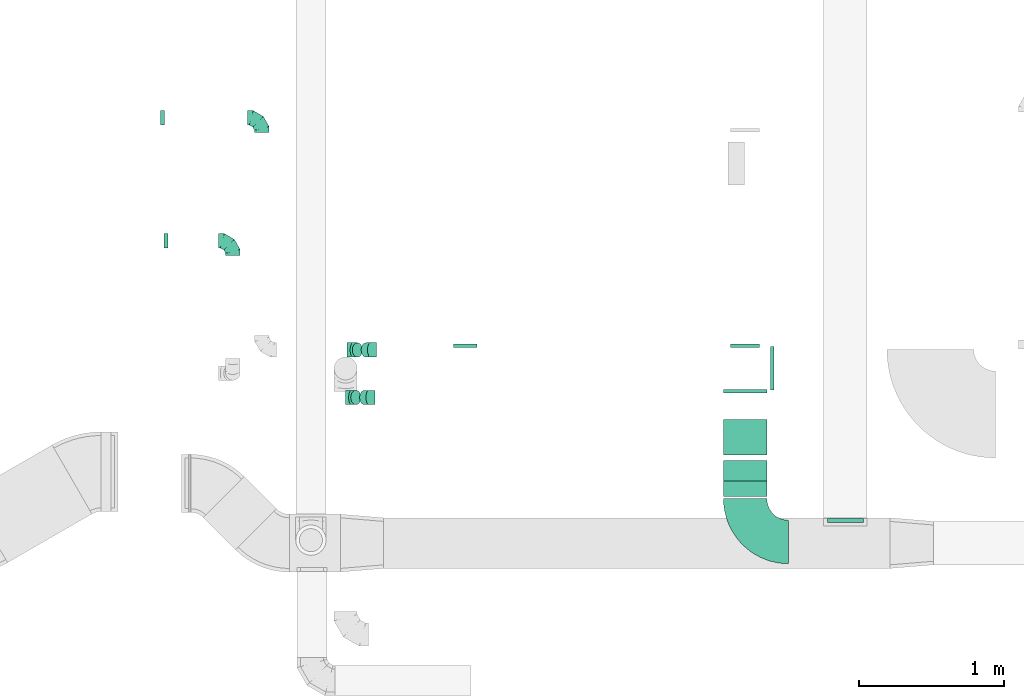
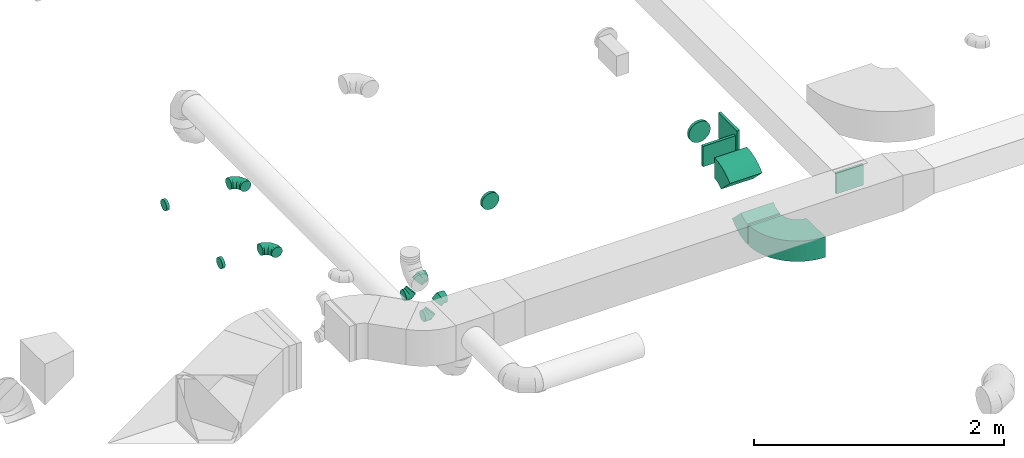
# One storey, part 48 of 62: 16 flow fittings.
"""IFC2X3 building model written with IfcOpenShell, lengths in millimetres."""

from ifc_helpers import new_model, entity, si_unit, converted_unit, derived_unit, direction, frame, frame_2d, origin, origin_2d_with_axis, place, context, subcontext, project, spatial, polyline, circle_curve, parameter, trimmed, segment, composite_curve, rectangle, outline, extrude, faceted_brep, source, transform, mapped, material, type_object, type_shapes, element, save


model = new_model("IFC2X3")

# Units and contexts
model_context = context("Model", 3, precision=0.01, world=origin(), true_north=direction((6.12303176911189e-17, 1.0)))
body_context = subcontext(model_context, "Body", "Model", "MODEL_VIEW")
ifc_project = project(units=[si_unit("LENGTHUNIT", "METRE", prefix="MILLI"), si_unit("AREAUNIT", "SQUARE_METRE"), si_unit("VOLUMEUNIT", "CUBIC_METRE"), converted_unit("PLANEANGLEUNIT", "DEGREE", entity("IfcRatioMeasure", 0.0174532925199433), si_unit("PLANEANGLEUNIT", "RADIAN"), dimensions=[0, 0, 0, 0, 0, 0, 0]), si_unit("MASSUNIT", "GRAM", prefix="KILO"), derived_unit("MASSDENSITYUNIT", [(si_unit("MASSUNIT", "GRAM", prefix="KILO"), 1), (si_unit("LENGTHUNIT", "METRE"), -3)]), derived_unit("MOMENTOFINERTIAUNIT", [(si_unit("LENGTHUNIT", "METRE"), 4)]), si_unit("TIMEUNIT", "SECOND"), si_unit("FREQUENCYUNIT", "HERTZ"), si_unit("THERMODYNAMICTEMPERATUREUNIT", "DEGREE_CELSIUS"), derived_unit("THERMALTRANSMITTANCEUNIT", [(si_unit("MASSUNIT", "GRAM", prefix="KILO"), 1), (si_unit("THERMODYNAMICTEMPERATUREUNIT", "KELVIN"), -1), (si_unit("TIMEUNIT", "SECOND"), -3)]), derived_unit("VOLUMETRICFLOWRATEUNIT", [(si_unit("LENGTHUNIT", "METRE"), 3), (si_unit("TIMEUNIT", "SECOND"), -1)]), derived_unit("MASSFLOWRATEUNIT", [(si_unit("MASSUNIT", "GRAM", prefix="KILO"), 1), (si_unit("TIMEUNIT", "SECOND"), -1)]), derived_unit("ROTATIONALFREQUENCYUNIT", [(si_unit("TIMEUNIT", "SECOND"), -1)]), si_unit("ELECTRICCURRENTUNIT", "AMPERE"), si_unit("ELECTRICVOLTAGEUNIT", "VOLT"), si_unit("POWERUNIT", "WATT"), si_unit("FORCEUNIT", "NEWTON", prefix="KILO"), si_unit("ILLUMINANCEUNIT", "LUX"), si_unit("LUMINOUSFLUXUNIT", "LUMEN"), si_unit("LUMINOUSINTENSITYUNIT", "CANDELA"), derived_unit("USERDEFINED", [(si_unit("MASSUNIT", "GRAM", prefix="KILO"), -1), (si_unit("LENGTHUNIT", "METRE"), -2), (si_unit("TIMEUNIT", "SECOND"), 3), (si_unit("LUMINOUSFLUXUNIT", "LUMEN"), 1)]), derived_unit("LINEARVELOCITYUNIT", [(si_unit("LENGTHUNIT", "METRE"), 1), (si_unit("TIMEUNIT", "SECOND"), -1)]), si_unit("PRESSUREUNIT", "PASCAL"), derived_unit("USERDEFINED", [(si_unit("LENGTHUNIT", "METRE"), -2), (si_unit("MASSUNIT", "GRAM", prefix="KILO"), 1), (si_unit("TIMEUNIT", "SECOND"), -2)]), derived_unit("LINEARFORCEUNIT", [(si_unit("MASSUNIT", "GRAM", prefix="KILO"), 1), (si_unit("LENGTHUNIT", "METRE"), 1), (si_unit("TIMEUNIT", "SECOND"), -2), (si_unit("LENGTHUNIT", "METRE"), -1)]), derived_unit("PLANARFORCEUNIT", [(si_unit("MASSUNIT", "GRAM", prefix="KILO"), 1), (si_unit("LENGTHUNIT", "METRE"), 1), (si_unit("TIMEUNIT", "SECOND"), -2), (si_unit("LENGTHUNIT", "METRE"), -2)])], contexts=[model_context])

# Site, building, storey
site_placement = place(None, origin())
site = spatial("IfcSite", under=ifc_project, at=site_placement, CompositionType="ELEMENT")
building_placement = place(site_placement, origin())
building = spatial("IfcBuilding", under=site, at=building_placement, CompositionType="ELEMENT")
storey_placement = place(building_placement, frame((0.0, 0.0, 24000.0)))
storey = spatial("IfcBuildingStorey", under=building, at=storey_placement, CompositionType="ELEMENT", Elevation=24000.0)

# Flow fittings
ifc_material = material()
duct_fitting_type_1 = type_object("IfcDuctFittingType", PredefinedType="NOTDEFINED", material=ifc_material)
shared_shape_1 = source(origin(), body_context, "Body", "SweptSolid", [
    extrude(rectangle(XDim=26.096000000001, YDim=300.0, at=origin_2d_with_axis()), frame((6.95, 0.0, -100.0)), (0.0, 0.0, 1.0), 200.0),
])
type_shapes(duct_fitting_type_1, [shared_shape_1])
flow_fitting_1_placement = place(storey_placement, frame((63690.02, 9932.41, 3625.0), z_axis=(0.0, 0.0, -1.0), x_axis=(0.0, -1.0, 0.0)))
element("IfcFlowFitting", 1, at=flow_fitting_1_placement, inside=storey, type_object=duct_fitting_type_1, material=ifc_material, context=body_context, shape_type="MappedRepresentation", body=[
    mapped(shared_shape_1, transform((0.0, 0.0, 0.0), scale=1.0)),
])
duct_fitting_type_2 = type_object("IfcDuctFittingType", PredefinedType="NOTDEFINED", material=ifc_material)
shared_shape_2 = source(origin(), body_context, "Body", "SweptSolid", [
    extrude(rectangle(XDim=250.0, YDim=26.0960000000122, at=origin_2d_with_axis()), frame((6.95, 0.0, -100.0), z_axis=(0.0, 0.0, 1.0), x_axis=(0.0, -1.0, 0.0)), (0.0, 0.0, 1.0), 200.0),
])
type_shapes(duct_fitting_type_2, [shared_shape_2])
flow_fitting_2_placement = place(storey_placement, frame((64382.65, 9025.02, 3650.0), z_axis=(0.0, 0.0, -1.0), x_axis=(0.0, 1.0, 0.0)))
element("IfcFlowFitting", 2, at=flow_fitting_2_placement, inside=storey, type_object=duct_fitting_type_2, material=ifc_material, context=body_context, shape_type="MappedRepresentation", body=[
    mapped(shared_shape_2, transform((0.0, 0.0, 0.0), scale=1.0)),
])
duct_fitting_type_3 = type_object("IfcDuctFittingType", PredefinedType="NOTDEFINED", material=ifc_material)
shared_shape_3 = source(origin(), body_context, "Body", "SweptSolid", [
    extrude(rectangle(XDim=24.9999999999999, YDim=300.0, at=origin_2d_with_axis()), frame((12.5, 0.0, -125.0)), (0.0, 0.0, 1.0), 250.0),
])
type_shapes(duct_fitting_type_3, [shared_shape_3])
flow_fitting_3_placement = place(storey_placement, frame((63865.52, 10082.41, 3625.0)))
element("IfcFlowFitting", 3, at=flow_fitting_3_placement, inside=storey, type_object=duct_fitting_type_3, material=ifc_material, context=body_context, shape_type="MappedRepresentation", body=[
    mapped(shared_shape_3, transform((0.0, 0.0, 0.0), scale=1.0)),
])
duct_fitting_type_4 = type_object("IfcDuctFittingType", PredefinedType="NOTDEFINED", material=ifc_material)
shared_shape_4 = source(origin(), body_context, "Body", "Brep", [
    faceted_brep([(-100.0, 0.0, -50.0), (-100.0, -12.94, -48.3), (-100.0, -25.0, -43.3), (-100.0, -35.36, -35.36), (-100.0, -43.3, -25.0), (-100.0, -48.3, -12.94), (-100.0, -50.0, 0.0), (-100.0, -48.3, 12.94), (-100.0, -43.3, 25.0), (-100.0, -35.36, 35.36), (-100.0, -25.0, 43.3), (-100.0, -12.94, 48.3), (-100.0, 0.0, 50.0), (-100.0, 12.94, 48.3), (-100.0, 25.0, 43.3), (-100.0, 35.36, 35.36), (-100.0, 43.3, 25.0), (-100.0, 48.3, 12.94), (-100.0, 50.0, 0.0), (-100.0, 48.3, -12.94), (-100.0, 43.3, -25.0), (-100.0, 35.36, -35.36), (-100.0, 25.0, -43.3), (-100.0, 12.94, -48.3), (-76.67, 12.94, 48.3), (-79.9, 25.0, 43.3), (-73.21, 0.0, 50.0), (-82.68, 35.36, 35.36), (-86.15, 48.3, 12.94), (-86.6, 50.0, 0.0), (-84.81, 43.3, 25.0), (-84.81, 43.3, -25.0), (-82.68, 35.36, -35.36), (-86.15, 48.3, -12.94), (-76.67, 12.94, -48.3), (-73.21, 0.0, -50.0), (-79.9, 25.0, -43.3), (-69.74, -12.94, -48.3), (-66.51, -25.0, -43.3), (-63.73, -35.36, -35.36), (-61.6, -43.3, -25.0), (-60.26, -48.3, -12.94), (-59.81, -50.0, 0.0), (-60.26, -48.3, 12.94), (-61.6, -43.3, 25.0), (-63.73, -35.36, 35.36), (-66.51, -25.0, 43.3), (-69.74, -12.94, 48.3), (-36.27, 36.27, 48.3), (-45.1, 45.1, 43.3), (-26.79, 26.79, 50.0), (-52.68, 52.68, 35.36), (-58.49, 58.49, 25.0), (-62.15, 62.15, 12.94), (-63.4, 63.4, 0.0), (-62.15, 62.15, -12.94), (-58.49, 58.49, -25.0), (-52.68, 52.68, -35.36), (-36.27, 36.27, -48.3), (-26.79, 26.79, -50.0), (-45.1, 45.1, -43.3), (-17.32, 17.32, -48.3), (-8.49, 8.49, -43.3), (-0.91, 0.91, -35.36), (4.9, -4.9, -25.0), (8.56, -8.56, -12.94), (9.81, -9.81, 0.0), (8.56, -8.56, 12.94), (4.9, -4.9, 25.0), (-0.91, 0.91, 35.36), (-8.49, 8.49, 43.3), (-17.32, 17.32, 48.3), (-12.94, 76.67, 48.3), (-25.0, 79.9, 43.3), (0.0, 73.21, 50.0), (-35.36, 82.68, 35.36), (-43.3, 84.81, 25.0), (-48.3, 86.15, 12.94), (-50.0, 86.6, 0.0), (-48.3, 86.15, -12.94), (-43.3, 84.81, -25.0), (-35.36, 82.68, -35.36), (-12.94, 76.67, -48.3), (0.0, 73.21, -50.0), (-25.0, 79.9, -43.3), (12.94, 69.74, -48.3), (25.0, 66.51, -43.3), (35.36, 63.73, -35.36), (43.3, 61.6, -25.0), (48.3, 60.26, -12.94), (50.0, 59.81, 0.0), (48.3, 60.26, 12.94), (43.3, 61.6, 25.0), (35.36, 63.73, 35.36), (25.0, 66.51, 43.3), (12.94, 69.74, 48.3), (-12.94, 100.0, -48.3), (-25.0, 100.0, -43.3), (-35.36, 100.0, -35.36), (-43.3, 100.0, -25.0), (-48.3, 100.0, -12.94), (-50.0, 100.0, 0.0), (-48.3, 100.0, 12.94), (-43.3, 100.0, 25.0), (-35.36, 100.0, 35.36), (-25.0, 100.0, 43.3), (-12.94, 100.0, 48.3), (0.0, 100.0, 50.0), (12.94, 100.0, 48.3), (25.0, 100.0, 43.3), (35.36, 100.0, 35.36), (43.3, 100.0, 25.0), (48.3, 100.0, 12.94), (50.0, 100.0, 0.0), (48.3, 100.0, -12.94), (43.3, 100.0, -25.0), (35.36, 100.0, -35.36), (25.0, 100.0, -43.3), (12.94, 100.0, -48.3), (0.0, 100.0, -50.0)], [[[0, 1, 2, 3, 4, 5, 6, 7, 8, 9, 10, 11, 12, 13, 14, 15, 16, 17, 18, 19, 20, 21, 22, 23]], [[24, 25, 14, 13]], [[26, 24, 13, 12]], [[14, 25, 27, 15]], [[28, 29, 18, 17]], [[30, 28, 17, 16]], [[15, 27, 30, 16]], [[20, 31, 32, 21]], [[33, 31, 20, 19]], [[18, 29, 33, 19]], [[34, 35, 0, 23]], [[36, 34, 23, 22]], [[32, 36, 22, 21]], [[2, 1, 37, 38]], [[3, 2, 38, 39]], [[0, 35, 37, 1]], [[5, 4, 40, 41]], [[6, 5, 41, 42]], [[3, 39, 40, 4]], [[6, 42, 43, 7]], [[7, 43, 44, 8]], [[8, 44, 45, 9]], [[10, 46, 47, 11]], [[11, 47, 26, 12]], [[10, 9, 45, 46]], [[48, 49, 25, 24]], [[50, 48, 24, 26]], [[27, 25, 49, 51]], [[52, 53, 28, 30]], [[51, 52, 30, 27]], [[29, 28, 53, 54]], [[55, 56, 31, 33]], [[54, 55, 33, 29]], [[57, 32, 31, 56]], [[58, 59, 35, 34]], [[60, 58, 34, 36]], [[57, 60, 36, 32]], [[37, 35, 59, 61]], [[38, 37, 61, 62]], [[39, 38, 62, 63]], [[41, 40, 64, 65]], [[42, 41, 65, 66]], [[63, 64, 40, 39]], [[43, 42, 66, 67]], [[44, 43, 67, 68]], [[68, 69, 45, 44]], [[46, 45, 69, 70]], [[47, 46, 70, 71]], [[26, 47, 71, 50]], [[72, 73, 49, 48]], [[74, 72, 48, 50]], [[51, 49, 73, 75]], [[76, 77, 53, 52]], [[75, 76, 52, 51]], [[54, 53, 77, 78]], [[79, 80, 56, 55]], [[78, 79, 55, 54]], [[81, 57, 56, 80]], [[82, 83, 59, 58]], [[84, 82, 58, 60]], [[81, 84, 60, 57]], [[61, 59, 83, 85]], [[62, 61, 85, 86]], [[63, 62, 86, 87]], [[65, 64, 88, 89]], [[66, 65, 89, 90]], [[87, 88, 64, 63]], [[67, 66, 90, 91]], [[68, 67, 91, 92]], [[92, 93, 69, 68]], [[70, 69, 93, 94]], [[71, 70, 94, 95]], [[50, 71, 95, 74]], [[96, 97, 98, 99, 100, 101, 102, 103, 104, 105, 106, 107, 108, 109, 110, 111, 112, 113, 114, 115, 116, 117, 118, 119]], [[72, 74, 107, 106]], [[73, 72, 106, 105]], [[75, 73, 105, 104]], [[77, 76, 103, 102]], [[78, 77, 102, 101]], [[75, 104, 103, 76]], [[78, 101, 100, 79]], [[79, 100, 99, 80]], [[80, 99, 98, 81]], [[96, 119, 83, 82]], [[97, 96, 82, 84]], [[84, 81, 98, 97]], [[83, 119, 118, 85]], [[85, 118, 117, 86]], [[86, 117, 116, 87]], [[88, 115, 114, 89]], [[89, 114, 113, 90]], [[87, 116, 115, 88]], [[91, 90, 113, 112]], [[92, 91, 112, 111]], [[93, 92, 111, 110]], [[95, 94, 109, 108]], [[74, 95, 108, 107]], [[110, 109, 94, 93]]]),
])
type_shapes(duct_fitting_type_4, [shared_shape_4])
for number, where, z_axis, x_axis in (
    (4, (60349.74, 11814.38, 3360.0), (0.0, 0.0, 1.0), (0.0, 1.0, 0.0)),
    (5, (60149.52, 10964.63, 3300.0), (0.0, 0.0, 1.0), (0.0, 1.0, 0.0)),
):
    element("IfcFlowFitting", number, at=place(storey_placement, frame(where, z_axis=z_axis, x_axis=x_axis)), inside=storey, type_object=duct_fitting_type_4, material=ifc_material, context=body_context, shape_type="MappedRepresentation", body=[
        mapped(shared_shape_4, transform((0.0, 0.0, 0.0), scale=1.0)),
    ])
duct_fitting_type_5 = type_object("IfcDuctFittingType", PredefinedType="NOTDEFINED", material=ifc_material)
shared_shape_5 = source(origin(), body_context, "Body", "Brep", [
    faceted_brep([(20.0, 0.0, -80.0), (20.0, 20.71, -77.27), (20.0, 40.0, -69.28), (20.0, 56.57, -56.57), (20.0, 69.28, -40.0), (20.0, 77.27, -20.71), (20.0, 80.0, 0.0), (20.0, 77.27, 20.71), (20.0, 69.28, 40.0), (20.0, 56.57, 56.57), (20.0, 40.0, 69.28), (20.0, 20.71, 77.27), (20.0, 0.0, 80.0), (20.0, -20.71, 77.27), (20.0, -40.0, 69.28), (20.0, -56.57, 56.57), (20.0, -69.28, 40.0), (20.0, -77.27, 20.71), (20.0, -80.0, 0.0), (20.0, -77.27, -20.71), (20.0, -69.28, -40.0), (20.0, -56.57, -56.57), (20.0, -40.0, -69.28), (20.0, -20.71, -77.27), (0.0, 0.0, 80.0), (-6.1, 0.0, 80.0), (-6.1, -20.71, 77.27), (0.0, -20.71, 77.27), (-6.1, -40.0, 69.28), (0.0, -40.0, 69.28), (0.0, -56.57, 56.57), (-6.1, -56.57, 56.57), (0.0, -69.28, 40.0), (-6.1, -69.28, 40.0), (-6.1, -77.27, 20.71), (0.0, -77.27, 20.71), (-6.1, -80.0, 0.0), (0.0, -80.0, 0.0), (-6.1, -77.27, -20.71), (0.0, -77.27, -20.71), (-6.1, -69.28, -40.0), (0.0, -69.28, -40.0), (0.0, -56.57, -56.57), (-6.1, -56.57, -56.57), (0.0, -40.0, -69.28), (-6.1, -40.0, -69.28), (-6.1, -20.71, -77.27), (0.0, -20.71, -77.27), (-6.1, 0.0, -80.0), (0.0, 0.0, -80.0), (-6.1, 20.71, -77.27), (0.0, 20.71, -77.27), (-6.1, 40.0, -69.28), (0.0, 40.0, -69.28), (0.0, 56.57, -56.57), (-6.1, 56.57, -56.57), (0.0, 69.28, -40.0), (-6.1, 69.28, -40.0), (-6.1, 77.27, -20.71), (0.0, 77.27, -20.71), (-6.1, 80.0, 0.0), (0.0, 80.0, 0.0), (-6.1, 77.27, 20.71), (0.0, 77.27, 20.71), (-6.1, 69.28, 40.0), (0.0, 69.28, 40.0), (0.0, 56.57, 56.57), (-6.1, 56.57, 56.57), (0.0, 40.0, 69.28), (-6.1, 40.0, 69.28), (-6.1, 20.71, 77.27), (0.0, 20.71, 77.27)], [[[0, 1, 2, 3, 4, 5, 6, 7, 8, 9, 10, 11, 12, 13, 14, 15, 16, 17, 18, 19, 20, 21, 22, 23]], [[13, 12, 24, 25, 26, 27]], [[14, 13, 27, 26, 28, 29]], [[30, 15, 14, 29, 28, 31]], [[17, 16, 32, 33, 34, 35]], [[18, 17, 35, 34, 36, 37]], [[32, 16, 15, 30, 31, 33]], [[19, 18, 37, 36, 38, 39]], [[20, 19, 39, 38, 40, 41]], [[42, 21, 20, 41, 40, 43]], [[23, 22, 44, 45, 46, 47]], [[0, 23, 47, 46, 48, 49]], [[44, 22, 21, 42, 43, 45]], [[1, 0, 49, 48, 50, 51]], [[2, 1, 51, 50, 52, 53]], [[54, 3, 2, 53, 52, 55]], [[5, 4, 56, 57, 58, 59]], [[6, 5, 59, 58, 60, 61]], [[56, 4, 3, 54, 55, 57]], [[7, 6, 61, 60, 62, 63]], [[8, 7, 63, 62, 64, 65]], [[66, 9, 8, 65, 64, 67]], [[11, 10, 68, 69, 70, 71]], [[12, 11, 71, 70, 25, 24]], [[68, 10, 9, 66, 67, 69]], [[46, 45, 43, 40, 38, 36, 34, 33, 31, 28, 26, 25, 70, 69, 67, 64, 62, 60, 58, 57, 55, 52, 50, 48]]]),
])
type_shapes(duct_fitting_type_5, [shared_shape_5])
flow_fitting_4_placement = place(storey_placement, frame((61755.59, 10232.41, 3625.0), z_axis=(0.0, 0.0, -1.0), x_axis=(0.0, 1.0, 0.0)))
element("IfcFlowFitting", 6, at=flow_fitting_4_placement, inside=storey, type_object=duct_fitting_type_5, material=ifc_material, context=body_context, shape_type="MappedRepresentation", body=[
    mapped(shared_shape_5, transform((0.0, 0.0, 0.0), scale=1.0)),
])
duct_fitting_type_6 = type_object("IfcDuctFittingType", PredefinedType="NOTDEFINED", material=ifc_material)
shared_shape_6 = source(origin(), body_context, "Body", "Brep", [
    faceted_brep([(-41.42, 0.0, -50.0), (-41.42, -12.94, -48.3), (-41.42, -25.0, -43.3), (-41.42, -35.36, -35.36), (-41.42, -43.3, -25.0), (-41.42, -48.3, -12.94), (-41.42, -50.0, 0.0), (-41.42, -48.3, 12.94), (-41.42, -43.3, 25.0), (-41.42, -35.36, 35.36), (-41.42, -25.0, 43.3), (-41.42, -12.94, 48.3), (-41.42, 0.0, 50.0), (-41.42, 12.94, 48.3), (-41.42, 25.0, 43.3), (-41.42, 35.36, 35.36), (-41.42, 43.3, 25.0), (-41.42, 48.3, 12.94), (-41.42, 50.0, 0.0), (-41.42, 48.3, -12.94), (-41.42, 43.3, -25.0), (-41.42, 35.36, -35.36), (-41.42, 25.0, -43.3), (-41.42, 12.94, -48.3), (-5.36, 12.94, 48.3), (-10.36, 25.0, 43.3), (0.0, 0.0, 50.0), (-14.64, 35.36, 35.36), (-20.0, 48.3, 12.94), (-20.71, 50.0, 0.0), (-17.94, 43.3, 25.0), (-17.94, 43.3, -25.0), (-14.64, 35.36, -35.36), (-20.0, 48.3, -12.94), (-5.36, 12.94, -48.3), (0.0, 0.0, -50.0), (-10.36, 25.0, -43.3), (5.36, -12.94, -48.3), (10.36, -25.0, -43.3), (14.64, -35.36, -35.36), (17.94, -43.3, -25.0), (20.0, -48.3, -12.94), (20.71, -50.0, 0.0), (20.0, -48.3, 12.94), (17.94, -43.3, 25.0), (14.64, -35.36, 35.36), (10.36, -25.0, 43.3), (5.36, -12.94, 48.3), (29.29, 29.29, 50.0), (20.14, 38.44, 48.3), (11.61, 46.97, 43.3), (4.29, 54.29, 35.36), (-1.33, 59.91, 25.0), (-4.86, 63.44, 12.94), (-6.07, 64.64, 0.0), (-4.86, 63.44, -12.94), (-1.33, 59.91, -25.0), (4.29, 54.29, -35.36), (11.61, 46.97, -43.3), (20.14, 38.44, -48.3), (29.29, 29.29, -50.0), (38.44, 20.14, -48.3), (46.97, 11.61, -43.3), (54.29, 4.29, -35.36), (59.91, -1.33, -25.0), (63.44, -4.86, -12.94), (64.64, -6.07, 0.0), (63.44, -4.86, 12.94), (59.91, -1.33, 25.0), (54.29, 4.29, 35.36), (46.97, 11.61, 43.3), (38.44, 20.14, 48.3)], [[[0, 1, 2, 3, 4, 5, 6, 7, 8, 9, 10, 11, 12, 13, 14, 15, 16, 17, 18, 19, 20, 21, 22, 23]], [[24, 25, 14, 13]], [[26, 24, 13, 12]], [[14, 25, 27, 15]], [[28, 29, 18, 17]], [[30, 28, 17, 16]], [[16, 15, 27, 30]], [[20, 31, 32, 21]], [[33, 31, 20, 19]], [[18, 29, 33, 19]], [[34, 35, 0, 23]], [[36, 34, 23, 22]], [[32, 36, 22, 21]], [[1, 0, 35, 37]], [[2, 1, 37, 38]], [[38, 39, 3, 2]], [[5, 4, 40, 41]], [[6, 5, 41, 42]], [[39, 40, 4, 3]], [[6, 42, 43, 7]], [[7, 43, 44, 8]], [[8, 44, 45, 9]], [[9, 45, 46, 10]], [[10, 46, 47, 11]], [[26, 12, 11, 47]], [[24, 26, 48, 49]], [[25, 24, 49, 50]], [[27, 25, 50, 51]], [[28, 30, 52, 53]], [[29, 28, 53, 54]], [[27, 51, 52, 30]], [[29, 54, 55, 33]], [[33, 55, 56, 31]], [[31, 56, 57, 32]], [[36, 58, 59, 34]], [[34, 59, 60, 35]], [[36, 32, 57, 58]], [[61, 62, 38, 37]], [[60, 61, 37, 35]], [[63, 39, 38, 62]], [[40, 64, 65, 41]], [[41, 65, 66, 42]], [[64, 40, 39, 63]], [[43, 42, 66, 67]], [[44, 43, 67, 68]], [[68, 69, 45, 44]], [[47, 46, 70, 71]], [[26, 47, 71, 48]], [[69, 70, 46, 45]], [[59, 58, 57, 56, 55, 54, 53, 52, 51, 50, 49, 48, 71, 70, 69, 68, 67, 66, 65, 64, 63, 62, 61, 60]]]),
])
type_shapes(duct_fitting_type_6, [shared_shape_6])
for number, where, z_axis, x_axis in (
    (7, (60969.87, 9881.53, 3000.0), (0.0, 1.0, 0.0), (-0.707106781186464, 0.0, -0.707106781186631)),
    (8, (61100.5, 10209.97, 3120.0), (0.0, -1.0, 0.0), (-1.0, 0.0, 0.0)),
    (9, (60980.5, 10209.97, 3000.0), (0.0, 1.0, 0.0), (-0.707106781186464, 0.0, -0.707106781186631)),
    (10, (61089.87, 9881.53, 3120.0), (0.0, 1.0, 0.0), (0.707106781186398, 0.0, 0.707106781186697)),
):
    element("IfcFlowFitting", number, at=place(storey_placement, frame(where, z_axis=z_axis, x_axis=x_axis)), inside=storey, type_object=duct_fitting_type_6, material=ifc_material, context=body_context, shape_type="MappedRepresentation", body=[
        mapped(shared_shape_6, transform((0.0, 0.0, 0.0), scale=1.0)),
    ])
duct_fitting_type_7 = type_object("IfcDuctFittingType", PredefinedType="NOTDEFINED", material=ifc_material)
shared_shape_7 = source(origin(), body_context, "Body", "Brep", [
    faceted_brep([(20.0, 0.0, -100.0), (20.0, 25.88, -96.59), (20.0, 50.0, -86.6), (20.0, 70.71, -70.71), (20.0, 86.6, -50.0), (20.0, 96.59, -25.88), (20.0, 100.0, 0.0), (20.0, 96.59, 25.88), (20.0, 86.6, 50.0), (20.0, 70.71, 70.71), (20.0, 50.0, 86.6), (20.0, 25.88, 96.59), (20.0, 0.0, 100.0), (20.0, -25.88, 96.59), (20.0, -50.0, 86.6), (20.0, -70.71, 70.71), (20.0, -86.6, 50.0), (20.0, -96.59, 25.88), (20.0, -100.0, 0.0), (20.0, -96.59, -25.88), (20.0, -86.6, -50.0), (20.0, -70.71, -70.71), (20.0, -50.0, -86.6), (20.0, -25.88, -96.59), (0.0, 0.0, 100.0), (-6.1, 0.0, 100.0), (-6.1, -25.88, 96.59), (0.0, -25.88, 96.59), (-6.1, -50.0, 86.6), (0.0, -50.0, 86.6), (0.0, -70.71, 70.71), (-6.1, -70.71, 70.71), (0.0, -86.6, 50.0), (-6.1, -86.6, 50.0), (-6.1, -96.59, 25.88), (0.0, -96.59, 25.88), (-6.1, -100.0, 0.0), (0.0, -100.0, 0.0), (-6.1, -96.59, -25.88), (0.0, -96.59, -25.88), (-6.1, -86.6, -50.0), (0.0, -86.6, -50.0), (0.0, -70.71, -70.71), (-6.1, -70.71, -70.71), (0.0, -50.0, -86.6), (-6.1, -50.0, -86.6), (-6.1, -25.88, -96.59), (0.0, -25.88, -96.59), (-6.1, 0.0, -100.0), (0.0, 0.0, -100.0), (-6.1, 25.88, -96.59), (0.0, 25.88, -96.59), (-6.1, 50.0, -86.6), (0.0, 50.0, -86.6), (0.0, 70.71, -70.71), (-6.1, 70.71, -70.71), (0.0, 86.6, -50.0), (-6.1, 86.6, -50.0), (-6.1, 96.59, -25.88), (0.0, 96.59, -25.88), (-6.1, 100.0, 0.0), (0.0, 100.0, 0.0), (-6.1, 96.59, 25.88), (0.0, 96.59, 25.88), (-6.1, 86.6, 50.0), (0.0, 86.6, 50.0), (0.0, 70.71, 70.71), (-6.1, 70.71, 70.71), (0.0, 50.0, 86.6), (-6.1, 50.0, 86.6), (-6.1, 25.88, 96.59), (0.0, 25.88, 96.59)], [[[0, 1, 2, 3, 4, 5, 6, 7, 8, 9, 10, 11, 12, 13, 14, 15, 16, 17, 18, 19, 20, 21, 22, 23]], [[13, 12, 24, 25, 26, 27]], [[14, 13, 27, 26, 28, 29]], [[30, 15, 14, 29, 28, 31]], [[17, 16, 32, 33, 34, 35]], [[18, 17, 35, 34, 36, 37]], [[32, 16, 15, 30, 31, 33]], [[19, 18, 37, 36, 38, 39]], [[20, 19, 39, 38, 40, 41]], [[42, 21, 20, 41, 40, 43]], [[23, 22, 44, 45, 46, 47]], [[0, 23, 47, 46, 48, 49]], [[44, 22, 21, 42, 43, 45]], [[1, 0, 49, 48, 50, 51]], [[2, 1, 51, 50, 52, 53]], [[54, 3, 2, 53, 52, 55]], [[5, 4, 56, 57, 58, 59]], [[6, 5, 59, 58, 60, 61]], [[56, 4, 3, 54, 55, 57]], [[7, 6, 61, 60, 62, 63]], [[8, 7, 63, 62, 64, 65]], [[66, 9, 8, 65, 64, 67]], [[11, 10, 68, 69, 70, 71]], [[12, 11, 71, 70, 25, 24]], [[68, 10, 9, 66, 67, 69]], [[46, 45, 43, 40, 38, 36, 34, 33, 31, 28, 26, 25, 70, 69, 67, 64, 62, 60, 58, 57, 55, 52, 50, 48]]]),
])
type_shapes(duct_fitting_type_7, [shared_shape_7])
flow_fitting_5_placement = place(storey_placement, frame((63690.02, 10232.41, 3625.0), z_axis=(0.0, 0.0, -1.0), x_axis=(0.0, 1.0, 0.0)))
element("IfcFlowFitting", 11, at=flow_fitting_5_placement, inside=storey, type_object=duct_fitting_type_7, material=ifc_material, context=body_context, shape_type="MappedRepresentation", body=[
    mapped(shared_shape_7, transform((0.0, 0.0, 0.0), scale=1.0)),
])
duct_fitting_type_8 = type_object("IfcDuctFittingType", PredefinedType="NOTDEFINED", material=ifc_material)
shared_shape_8 = source(origin(), body_context, "Body", "Brep", [
    faceted_brep([(20.0, 12.94, -48.3), (20.0, 25.0, -43.3), (20.0, 35.36, -35.36), (20.0, 43.3, -25.0), (20.0, 48.3, -12.94), (20.0, 50.0, 0.0), (20.0, 48.3, 12.94), (20.0, 43.3, 25.0), (20.0, 35.36, 35.36), (20.0, 25.0, 43.3), (20.0, 12.94, 48.3), (20.0, 0.0, 50.0), (20.0, -12.94, 48.3), (20.0, -25.0, 43.3), (20.0, -35.36, 35.36), (20.0, -43.3, 25.0), (20.0, -48.3, 12.94), (20.0, -50.0, 0.0), (20.0, -48.3, -12.94), (20.0, -43.3, -25.0), (20.0, -35.36, -35.36), (20.0, -25.0, -43.3), (20.0, -12.94, -48.3), (20.0, 0.0, -50.0), (0.0, 0.0, 50.0), (0.0, 12.94, 48.3), (-6.1, 12.94, 48.3), (-6.1, 0.0, 50.0), (0.0, 25.0, 43.3), (-6.1, 25.0, 43.3), (0.0, 35.36, 35.36), (-6.1, 35.36, 35.36), (0.0, 43.3, 25.0), (0.0, 48.3, 12.94), (-6.1, 48.3, 12.94), (-6.1, 43.3, 25.0), (0.0, 50.0, 0.0), (-6.1, 50.0, 0.0), (0.0, 48.3, -12.94), (-6.1, 48.3, -12.94), (0.0, 43.3, -25.0), (-6.1, 43.3, -25.0), (0.0, 35.36, -35.36), (-6.1, 35.36, -35.36), (0.0, 25.0, -43.3), (0.0, 12.94, -48.3), (-6.1, 12.94, -48.3), (-6.1, 25.0, -43.3), (0.0, 0.0, -50.0), (-6.1, 0.0, -50.0), (0.0, -12.94, -48.3), (-6.1, -12.94, -48.3), (0.0, -25.0, -43.3), (-6.1, -25.0, -43.3), (0.0, -35.36, -35.36), (-6.1, -35.36, -35.36), (0.0, -43.3, -25.0), (0.0, -48.3, -12.94), (-6.1, -48.3, -12.94), (-6.1, -43.3, -25.0), (0.0, -50.0, 0.0), (-6.1, -50.0, 0.0), (0.0, -48.3, 12.94), (-6.1, -48.3, 12.94), (0.0, -43.3, 25.0), (-6.1, -43.3, 25.0), (0.0, -35.36, 35.36), (-6.1, -35.36, 35.36), (0.0, -25.0, 43.3), (0.0, -12.94, 48.3), (-6.1, -12.94, 48.3), (-6.1, -25.0, 43.3)], [[[0, 1, 2, 3, 4, 5, 6, 7, 8, 9, 10, 11, 12, 13, 14, 15, 16, 17, 18, 19, 20, 21, 22, 23]], [[24, 11, 10, 25, 26, 27]], [[25, 10, 9, 28, 29, 26]], [[28, 9, 8, 30, 31, 29]], [[32, 7, 6, 33, 34, 35]], [[33, 6, 5, 36, 37, 34]], [[30, 8, 7, 32, 35, 31]], [[36, 5, 4, 38, 39, 37]], [[38, 4, 3, 40, 41, 39]], [[40, 3, 2, 42, 43, 41]], [[44, 1, 0, 45, 46, 47]], [[45, 0, 23, 48, 49, 46]], [[42, 2, 1, 44, 47, 43]], [[48, 23, 22, 50, 51, 49]], [[50, 22, 21, 52, 53, 51]], [[52, 21, 20, 54, 55, 53]], [[56, 19, 18, 57, 58, 59]], [[57, 18, 17, 60, 61, 58]], [[54, 20, 19, 56, 59, 55]], [[60, 17, 16, 62, 63, 61]], [[62, 16, 15, 64, 65, 63]], [[64, 15, 14, 66, 67, 65]], [[68, 13, 12, 69, 70, 71]], [[69, 12, 11, 24, 27, 70]], [[66, 14, 13, 68, 71, 67]], [[49, 51, 53, 55, 59, 58, 61, 63, 65, 67, 71, 70, 27, 26, 29, 31, 35, 34, 37, 39, 41, 43, 47, 46]]]),
])
type_shapes(duct_fitting_type_8, [shared_shape_8])
for number, where, z_axis, x_axis in (
    (12, (59655.69, 11814.38, 3360.0), (0.0, -1.0, 0.0), (1.0, 0.0, 0.0)),
    (13, (59680.56, 10964.63, 3300.0), (0.0, -1.0, 0.0), (1.0, 0.0, 0.0)),
):
    element("IfcFlowFitting", number, at=place(storey_placement, frame(where, z_axis=z_axis, x_axis=x_axis)), inside=storey, type_object=duct_fitting_type_8, material=ifc_material, context=body_context, shape_type="MappedRepresentation", body=[
        mapped(shared_shape_8, transform((0.0, 0.0, 0.0), scale=1.0)),
    ])
duct_fitting_type_9 = type_object("IfcDuctFittingType", PredefinedType="NOTDEFINED", material=ifc_material)
shared_shape_9 = source(origin(), body_context, "Body", "SweptSolid", [
    extrude(outline(composite_curve([segment(polyline([(-300.0, -150.0), (0.0, -150.0)]), True, "CONTINUOUS"), segment(trimmed(circle_curve(frame_2d((150.0, -150.0), x_axis=(0.0, 1.0)), 150.0), [parameter(0.0)], [parameter(90.0)], True, "PARAMETER"), False, "CONTINUOUS"), segment(polyline([(150.0, 0.0), (150.0, 300.0)]), True, "CONTINUOUS"), segment(trimmed(circle_curve(frame_2d((150.0, -150.0), x_axis=(0.0, 1.0)), 450.0), [parameter(0.0)], [parameter(90.0000000000001)], True, "PARAMETER"), True, "CONTINUOUS")], self_intersect=False)), frame((-150.0, 150.0, -100.0), z_axis=(0.0, 0.0, 1.0), x_axis=(-1.0, 0.0, 0.0)), (0.0, 0.0, 1.0), 200.0),
])
type_shapes(duct_fitting_type_9, [shared_shape_9])
flow_fitting_6_placement = place(storey_placement, frame((63690.02, 8882.41, 3300.0), z_axis=(0.0, 0.0, 1.0), x_axis=(0.0, -1.0, 0.0)))
element("IfcFlowFitting", 14, at=flow_fitting_6_placement, inside=storey, type_object=duct_fitting_type_9, material=ifc_material, context=body_context, shape_type="MappedRepresentation", body=[
    mapped(shared_shape_9, transform((0.0, 0.0, 0.0), scale=1.0)),
])
duct_fitting_type_10 = type_object("IfcDuctFittingType", PredefinedType="NOTDEFINED", material=ifc_material)
shared_shape_10 = source(origin(), body_context, "Body", "SweptSolid", [
    extrude(outline(composite_curve([segment(polyline([(-136.61, -88.39), (63.39, -88.39)]), True, "CONTINUOUS"), segment(trimmed(circle_curve(frame_2d((213.39, -88.39), x_axis=(-0.707106781186546, 0.707106781186546)), 150.0), [parameter(0.0)], [parameter(45.0)], True, "PARAMETER"), False, "CONTINUOUS"), segment(polyline([(107.32, 17.68), (-34.1, 159.1)]), True, "CONTINUOUS"), segment(trimmed(circle_curve(frame_2d((213.39, -88.39), x_axis=(-0.707106781186546, 0.707106781186546)), 350.0), [parameter(0.0)], [parameter(45.0)], True, "PARAMETER"), True, "CONTINUOUS")], self_intersect=False)), frame((-15.17, 36.61, -150.0), z_axis=(0.0, 0.0, 1.0), x_axis=(-0.707106781186547, 0.707106781186548, 0.0)), (0.0, 0.0, 1.0), 300.0),
])
type_shapes(duct_fitting_type_10, [shared_shape_10])
for number, where, z_axis, x_axis in (
    (15, (63690.02, 9302.39, 3300.0), (1.0, 0.0, 0.0), (0.0, 1.0, 0.0)),
    (16, (63690.02, 9627.39, 3625.0), (-1.0, 0.0, 0.0), (0.0, 0.707106781186528, 0.707106781186567)),
):
    element("IfcFlowFitting", number, at=place(storey_placement, frame(where, z_axis=z_axis, x_axis=x_axis)), inside=storey, type_object=duct_fitting_type_10, material=ifc_material, context=body_context, shape_type="MappedRepresentation", body=[
        mapped(shared_shape_10, transform((0.0, 0.0, 0.0), scale=1.0)),
    ])

save(model, "model.ifc")
